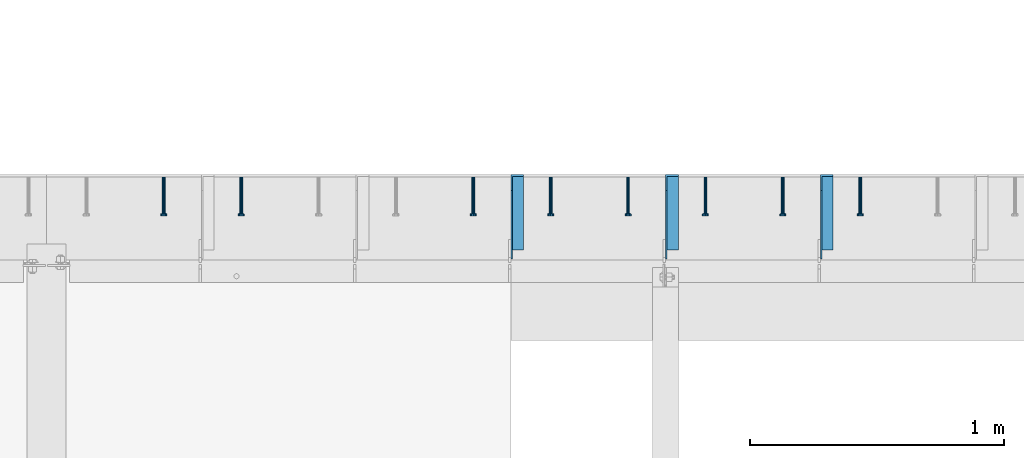
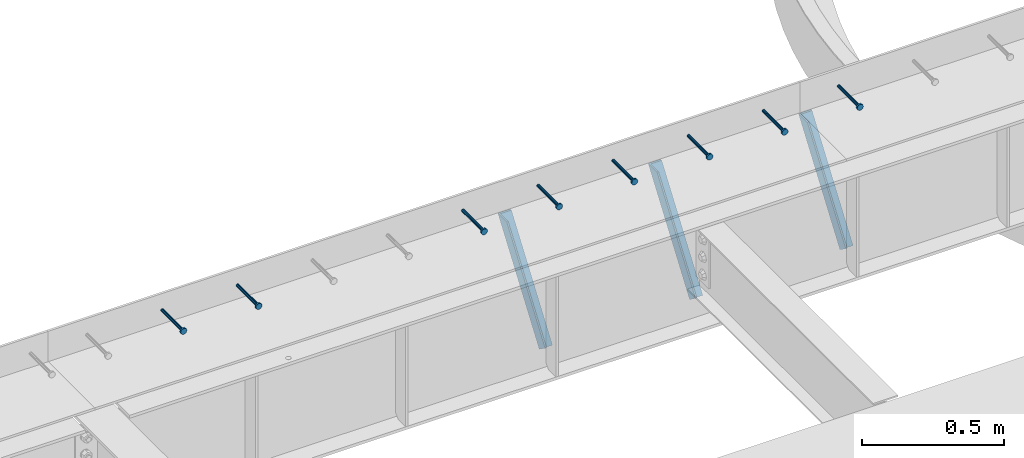
# One storey, part 1348 of 1763: 8 beams, 3 members, 9 elements without a shape of their own.
"""IFC2X3 building model written with IfcOpenShell, lengths in millimetres."""

from ifc_helpers import new_model, si_unit, frame, origin_with_axes, place, context, subcontext, project, spatial, faceted_brep, material, type_object, element, aggregate, save


model = new_model("IFC2X3")

# Units and contexts
model_context = context("Model", 3, precision=1e-05, world=origin_with_axes())
body_context = subcontext(model_context, "Body", "Model", "MODEL_VIEW")
ifc_project = project(units=[si_unit("LENGTHUNIT", "METRE", prefix="MILLI"), si_unit("AREAUNIT", "SQUARE_METRE"), si_unit("VOLUMEUNIT", "CUBIC_METRE"), si_unit("MASSUNIT", "GRAM", prefix="KILO"), si_unit("TIMEUNIT", "SECOND"), si_unit("PLANEANGLEUNIT", "RADIAN"), si_unit("SOLIDANGLEUNIT", "STERADIAN"), si_unit("THERMODYNAMICTEMPERATUREUNIT", "DEGREE_CELSIUS"), si_unit("LUMINOUSINTENSITYUNIT", "LUMEN")], contexts=[model_context])

# Site, building, storey
site_placement = place(None, origin_with_axes())
site = spatial("IfcSite", under=ifc_project, at=site_placement, CompositionType="ELEMENT")
building_placement = place(site_placement, origin_with_axes())
building = spatial("IfcBuilding", under=site, at=building_placement, Name="Undefined", CompositionType="ELEMENT")
storey_placement = place(building_placement, origin_with_axes())
storey = spatial("IfcBuildingStorey", under=building, at=storey_placement, Name="Undefined", CompositionType="ELEMENT", Elevation=0.0)

# Assembly, beam
assembly_1_placement = place(storey_placement, origin_with_axes())
assembly_1 = element("IfcElementAssembly", 1, at=assembly_1_placement, inside=storey, Name="HEADED STUD ANCHOR", AssemblyPlace="NOTDEFINED", PredefinedType="RIGID_FRAME")
ifc_material_1 = material(Name="STEEL/A108")
beam_type = type_object("IfcBeamType", PredefinedType="NOTDEFINED")
beam_1_placement = place(assembly_1_placement, frame((-58389.2747736983, 53984.5250183106, 5264.23140606069), z_axis=(0.0, 0.0, 1.0), x_axis=(0.0, -1.0, 0.0)))
beam_1 = element("IfcBeam", 2, at=beam_1_placement, type_object=beam_type, material=ifc_material_1, Name="HEADED STUD ANCHOR", context=body_context, shape_type="Brep", body=[
    faceted_brep([(0.0, -3.1800000667572, 5.5), (0.0, -5.5, 3.1800000667572), (141.732000000002, -5.5, 3.1800000667572), (141.732000000002, -3.1800000667572, 5.5), (0.0, -6.34999999999491, 1.45519152283669e-11), (141.732000000002, -6.34999990463257, 0.0), (0.0, -5.5, -3.1800000667572), (141.732000000002, -5.5, -3.1800000667572), (0.0, -3.1800000667572, -5.5), (141.732000000002, -3.1800000667572, -5.5), (0.0, 0.0, -6.34999990463257), (141.732000000002, 0.0, -6.34999990463257), (0.0, 3.1800000667572, -5.5), (141.732000000002, 3.1800000667572, -5.5), (0.0, 5.5, -3.1800000667572), (141.732000000002, 5.5, -3.1800000667572), (0.0, 6.34999999999491, -2.91038304567337e-11), (141.732000000002, 6.34999990463257, 0.0), (0.0, 5.5, 3.1800000667572), (141.732000000002, 5.5, 3.1800000667572), (0.0, 3.1800000667572, 5.5), (141.732000000002, 3.1800000667572, 5.5), (0.0, 0.0, 6.34999990463257), (141.732000000002, 0.0, 6.34999990463257), (144.780000000001, -10.9899997711182, 6.34999990463257), (144.780000000001, -6.34000015258789, 10.9899997711182), (144.780000000001, -12.6999998092651, 0.0), (144.780000000001, -10.9899997711182, -6.34999990463257), (144.780000000001, -6.34000015258789, -10.9899997711182), (144.780000000001, 0.0, -12.6899995803833), (144.780000000001, 6.34000015258789, -10.9899997711182), (144.780000000001, 10.9899997711182, -6.34999990463257), (144.780000000001, 12.6999998092651, 0.0), (144.780000000001, 10.9899997711182, 6.34999990463257), (144.780000000001, 6.34000015258789, 10.9899997711182), (144.780000000001, 0.0, 12.6899995803833), (152.400000000001, -10.9899997711182, 6.34999990463257), (152.400000000001, -6.34000015258789, 10.9899997711182), (152.400000000001, -12.6999998092651, 0.0), (152.400000000001, -10.9899997711182, -6.34999990463257), (152.400000000001, -6.34000015258789, -10.9899997711182), (152.400000000001, 0.0, -12.6899995803833), (152.400000000001, 6.34000015258789, -10.9899997711182), (152.400000000001, 10.9899997711182, -6.34999990463257), (152.400000000001, 12.6999998092651, 0.0), (152.400000000001, 10.9899997711182, 6.34999990463257), (152.400000000001, 6.34000015258789, 10.9899997711182), (152.400000000001, 0.0, 12.6899995803833)], [[[0, 1, 2, 3]], [[1, 4, 5, 2]], [[4, 6, 7, 5]], [[6, 8, 9, 7]], [[8, 10, 11, 9]], [[10, 12, 13, 11]], [[12, 14, 15, 13]], [[14, 16, 17, 15]], [[16, 18, 19, 17]], [[18, 20, 21, 19]], [[20, 22, 23, 21]], [[22, 0, 3, 23]], [[22, 20, 18, 16, 14, 12, 10, 8, 6, 4, 1, 0]], [[3, 2, 24, 25]], [[2, 5, 26, 24]], [[5, 7, 27, 26]], [[7, 9, 28, 27]], [[9, 11, 29, 28]], [[11, 13, 30, 29]], [[13, 15, 31, 30]], [[15, 17, 32, 31]], [[17, 19, 33, 32]], [[19, 21, 34, 33]], [[21, 23, 35, 34]], [[23, 3, 25, 35]], [[25, 24, 36, 37]], [[24, 26, 38, 36]], [[26, 27, 39, 38]], [[27, 28, 40, 39]], [[28, 29, 41, 40]], [[29, 30, 42, 41]], [[30, 31, 43, 42]], [[31, 32, 44, 43]], [[32, 33, 45, 44]], [[33, 34, 46, 45]], [[34, 35, 47, 46]], [[35, 25, 37, 47]], [[38, 39, 40, 41, 42, 43, 44, 45, 46, 47, 37, 36]]]),
])
aggregate(assembly_1, [beam_1])

assembly_2_placement = place(storey_placement, origin_with_axes())
assembly_2 = element("IfcElementAssembly", 3, at=assembly_2_placement, inside=storey, Name="HEADED STUD ANCHOR", AssemblyPlace="NOTDEFINED", PredefinedType="RIGID_FRAME")
beam_2_placement = place(assembly_2_placement, frame((-58694.0747736983, 53984.5250183106, 5264.23140606069), z_axis=(0.0, 0.0, 1.0), x_axis=(0.0, -1.0, 0.0)))
beam_2 = element("IfcBeam", 4, at=beam_2_placement, type_object=beam_type, material=ifc_material_1, Name="HEADED STUD ANCHOR", context=body_context, shape_type="Brep", body=[
    faceted_brep([(0.0, -3.1800000667572, 5.5), (0.0, -5.5, 3.1800000667572), (141.732000000002, -5.5, 3.1800000667572), (141.732000000002, -3.1800000667572, 5.5), (0.0, -6.34999999999491, 1.45519152283669e-11), (141.732000000002, -6.34999990463257, 0.0), (0.0, -5.5, -3.1800000667572), (141.732000000002, -5.5, -3.1800000667572), (0.0, -3.1800000667572, -5.5), (141.732000000002, -3.1800000667572, -5.5), (0.0, 0.0, -6.34999990463257), (141.732000000002, 0.0, -6.34999990463257), (0.0, 3.1800000667572, -5.5), (141.732000000002, 3.1800000667572, -5.5), (0.0, 5.5, -3.1800000667572), (141.732000000002, 5.5, -3.1800000667572), (0.0, 6.34999999999491, -2.91038304567337e-11), (141.732000000002, 6.34999990463257, 0.0), (0.0, 5.5, 3.1800000667572), (141.732000000002, 5.5, 3.1800000667572), (0.0, 3.1800000667572, 5.5), (141.732000000002, 3.1800000667572, 5.5), (0.0, 0.0, 6.34999990463257), (141.732000000002, 0.0, 6.34999990463257), (144.780000000001, -10.9899997711182, 6.34999990463257), (144.780000000001, -6.34000015258789, 10.9899997711182), (144.780000000001, -12.6999998092651, 0.0), (144.780000000001, -10.9899997711182, -6.34999990463257), (144.780000000001, -6.34000015258789, -10.9899997711182), (144.780000000001, 0.0, -12.6899995803833), (144.780000000001, 6.34000015258789, -10.9899997711182), (144.780000000001, 10.9899997711182, -6.34999990463257), (144.780000000001, 12.6999998092651, 0.0), (144.780000000001, 10.9899997711182, 6.34999990463257), (144.780000000001, 6.34000015258789, 10.9899997711182), (144.780000000001, 0.0, 12.6899995803833), (152.400000000001, -10.9899997711182, 6.34999990463257), (152.400000000001, -6.34000015258789, 10.9899997711182), (152.400000000001, -12.6999998092651, 0.0), (152.400000000001, -10.9899997711182, -6.34999990463257), (152.400000000001, -6.34000015258789, -10.9899997711182), (152.400000000001, 0.0, -12.6899995803833), (152.400000000001, 6.34000015258789, -10.9899997711182), (152.400000000001, 10.9899997711182, -6.34999990463257), (152.400000000001, 12.6999998092651, 0.0), (152.400000000001, 10.9899997711182, 6.34999990463257), (152.400000000001, 6.34000015258789, 10.9899997711182), (152.400000000001, 0.0, 12.6899995803833)], [[[0, 1, 2, 3]], [[1, 4, 5, 2]], [[4, 6, 7, 5]], [[6, 8, 9, 7]], [[8, 10, 11, 9]], [[10, 12, 13, 11]], [[12, 14, 15, 13]], [[14, 16, 17, 15]], [[16, 18, 19, 17]], [[18, 20, 21, 19]], [[20, 22, 23, 21]], [[22, 0, 3, 23]], [[22, 20, 18, 16, 14, 12, 10, 8, 6, 4, 1, 0]], [[3, 2, 24, 25]], [[2, 5, 26, 24]], [[5, 7, 27, 26]], [[7, 9, 28, 27]], [[9, 11, 29, 28]], [[11, 13, 30, 29]], [[13, 15, 31, 30]], [[15, 17, 32, 31]], [[17, 19, 33, 32]], [[19, 21, 34, 33]], [[21, 23, 35, 34]], [[23, 3, 25, 35]], [[25, 24, 36, 37]], [[24, 26, 38, 36]], [[26, 27, 39, 38]], [[27, 28, 40, 39]], [[28, 29, 41, 40]], [[29, 30, 42, 41]], [[30, 31, 43, 42]], [[31, 32, 44, 43]], [[32, 33, 45, 44]], [[33, 34, 46, 45]], [[34, 35, 47, 46]], [[35, 25, 37, 47]], [[38, 39, 40, 41, 42, 43, 44, 45, 46, 47, 37, 36]]]),
])
aggregate(assembly_2, [beam_2])

assembly_3_placement = place(storey_placement, origin_with_axes())
assembly_3 = element("IfcElementAssembly", 5, at=assembly_3_placement, inside=storey, Name="HEADED STUD ANCHOR", AssemblyPlace="NOTDEFINED", PredefinedType="RIGID_FRAME")
beam_3_placement = place(assembly_3_placement, frame((-58998.8747736983, 53984.5250183106, 5264.23140606069), z_axis=(0.0, 0.0, 1.0), x_axis=(0.0, -1.0, 0.0)))
beam_3 = element("IfcBeam", 6, at=beam_3_placement, type_object=beam_type, material=ifc_material_1, Name="HEADED STUD ANCHOR", context=body_context, shape_type="Brep", body=[
    faceted_brep([(0.0, -3.1800000667572, 5.5), (0.0, -5.5, 3.1800000667572), (141.732000000002, -5.5, 3.1800000667572), (141.732000000002, -3.1800000667572, 5.5), (0.0, -6.34999999999491, 1.45519152283669e-11), (141.732000000002, -6.34999990463257, 0.0), (0.0, -5.5, -3.1800000667572), (141.732000000002, -5.5, -3.1800000667572), (0.0, -3.1800000667572, -5.5), (141.732000000002, -3.1800000667572, -5.5), (0.0, 0.0, -6.34999990463257), (141.732000000002, 0.0, -6.34999990463257), (0.0, 3.1800000667572, -5.5), (141.732000000002, 3.1800000667572, -5.5), (0.0, 5.5, -3.1800000667572), (141.732000000002, 5.5, -3.1800000667572), (0.0, 6.34999999999491, -2.91038304567337e-11), (141.732000000002, 6.34999990463257, 0.0), (0.0, 5.5, 3.1800000667572), (141.732000000002, 5.5, 3.1800000667572), (0.0, 3.1800000667572, 5.5), (141.732000000002, 3.1800000667572, 5.5), (0.0, 0.0, 6.34999990463257), (141.732000000002, 0.0, 6.34999990463257), (144.780000000001, -10.9899997711182, 6.34999990463257), (144.780000000001, -6.34000015258789, 10.9899997711182), (144.780000000001, -12.6999998092651, 0.0), (144.780000000001, -10.9899997711182, -6.34999990463257), (144.780000000001, -6.34000015258789, -10.9899997711182), (144.780000000001, 0.0, -12.6899995803833), (144.780000000001, 6.34000015258789, -10.9899997711182), (144.780000000001, 10.9899997711182, -6.34999990463257), (144.780000000001, 12.6999998092651, 0.0), (144.780000000001, 10.9899997711182, 6.34999990463257), (144.780000000001, 6.34000015258789, 10.9899997711182), (144.780000000001, 0.0, 12.6899995803833), (152.400000000001, -10.9899997711182, 6.34999990463257), (152.400000000001, -6.34000015258789, 10.9899997711182), (152.400000000001, -12.6999998092651, 0.0), (152.400000000001, -10.9899997711182, -6.34999990463257), (152.400000000001, -6.34000015258789, -10.9899997711182), (152.400000000001, 0.0, -12.6899995803833), (152.400000000001, 6.34000015258789, -10.9899997711182), (152.400000000001, 10.9899997711182, -6.34999990463257), (152.400000000001, 12.6999998092651, 0.0), (152.400000000001, 10.9899997711182, 6.34999990463257), (152.400000000001, 6.34000015258789, 10.9899997711182), (152.400000000001, 0.0, 12.6899995803833)], [[[0, 1, 2, 3]], [[1, 4, 5, 2]], [[4, 6, 7, 5]], [[6, 8, 9, 7]], [[8, 10, 11, 9]], [[10, 12, 13, 11]], [[12, 14, 15, 13]], [[14, 16, 17, 15]], [[16, 18, 19, 17]], [[18, 20, 21, 19]], [[20, 22, 23, 21]], [[22, 0, 3, 23]], [[22, 20, 18, 16, 14, 12, 10, 8, 6, 4, 1, 0]], [[3, 2, 24, 25]], [[2, 5, 26, 24]], [[5, 7, 27, 26]], [[7, 9, 28, 27]], [[9, 11, 29, 28]], [[11, 13, 30, 29]], [[13, 15, 31, 30]], [[15, 17, 32, 31]], [[17, 19, 33, 32]], [[19, 21, 34, 33]], [[21, 23, 35, 34]], [[23, 3, 25, 35]], [[25, 24, 36, 37]], [[24, 26, 38, 36]], [[26, 27, 39, 38]], [[27, 28, 40, 39]], [[28, 29, 41, 40]], [[29, 30, 42, 41]], [[30, 31, 43, 42]], [[31, 32, 44, 43]], [[32, 33, 45, 44]], [[33, 34, 46, 45]], [[34, 35, 47, 46]], [[35, 25, 37, 47]], [[38, 39, 40, 41, 42, 43, 44, 45, 46, 47, 37, 36]]]),
])
aggregate(assembly_3, [beam_3])

assembly_4_placement = place(storey_placement, origin_with_axes())
assembly_4 = element("IfcElementAssembly", 7, at=assembly_4_placement, inside=storey, Name="HEADED STUD ANCHOR", AssemblyPlace="NOTDEFINED", PredefinedType="RIGID_FRAME")
beam_4_placement = place(assembly_4_placement, frame((-59303.6747736983, 53984.5250183106, 5264.23140606069), z_axis=(0.0, 0.0, 1.0), x_axis=(0.0, -1.0, 0.0)))
beam_4 = element("IfcBeam", 8, at=beam_4_placement, type_object=beam_type, material=ifc_material_1, Name="HEADED STUD ANCHOR", context=body_context, shape_type="Brep", body=[
    faceted_brep([(0.0, -3.1800000667572, 5.5), (0.0, -5.5, 3.1800000667572), (141.732000000002, -5.5, 3.1800000667572), (141.732000000002, -3.1800000667572, 5.5), (0.0, -6.34999999999491, 1.45519152283669e-11), (141.732000000002, -6.34999990463257, 0.0), (0.0, -5.5, -3.1800000667572), (141.732000000002, -5.5, -3.1800000667572), (0.0, -3.1800000667572, -5.5), (141.732000000002, -3.1800000667572, -5.5), (0.0, 0.0, -6.34999990463257), (141.732000000002, 0.0, -6.34999990463257), (0.0, 3.1800000667572, -5.5), (141.732000000002, 3.1800000667572, -5.5), (0.0, 5.5, -3.1800000667572), (141.732000000002, 5.5, -3.1800000667572), (0.0, 6.34999999999491, -2.91038304567337e-11), (141.732000000002, 6.34999990463257, 0.0), (0.0, 5.5, 3.1800000667572), (141.732000000002, 5.5, 3.1800000667572), (0.0, 3.1800000667572, 5.5), (141.732000000002, 3.1800000667572, 5.5), (0.0, 0.0, 6.34999990463257), (141.732000000002, 0.0, 6.34999990463257), (144.780000000001, -10.9899997711182, 6.34999990463257), (144.780000000001, -6.34000015258789, 10.9899997711182), (144.780000000001, -12.6999998092651, 0.0), (144.780000000001, -10.9899997711182, -6.34999990463257), (144.780000000001, -6.34000015258789, -10.9899997711182), (144.780000000001, 0.0, -12.6899995803833), (144.780000000001, 6.34000015258789, -10.9899997711182), (144.780000000001, 10.9899997711182, -6.34999990463257), (144.780000000001, 12.6999998092651, 0.0), (144.780000000001, 10.9899997711182, 6.34999990463257), (144.780000000001, 6.34000015258789, 10.9899997711182), (144.780000000001, 0.0, 12.6899995803833), (152.400000000001, -10.9899997711182, 6.34999990463257), (152.400000000001, -6.34000015258789, 10.9899997711182), (152.400000000001, -12.6999998092651, 0.0), (152.400000000001, -10.9899997711182, -6.34999990463257), (152.400000000001, -6.34000015258789, -10.9899997711182), (152.400000000001, 0.0, -12.6899995803833), (152.400000000001, 6.34000015258789, -10.9899997711182), (152.400000000001, 10.9899997711182, -6.34999990463257), (152.400000000001, 12.6999998092651, 0.0), (152.400000000001, 10.9899997711182, 6.34999990463257), (152.400000000001, 6.34000015258789, 10.9899997711182), (152.400000000001, 0.0, 12.6899995803833)], [[[0, 1, 2, 3]], [[1, 4, 5, 2]], [[4, 6, 7, 5]], [[6, 8, 9, 7]], [[8, 10, 11, 9]], [[10, 12, 13, 11]], [[12, 14, 15, 13]], [[14, 16, 17, 15]], [[16, 18, 19, 17]], [[18, 20, 21, 19]], [[20, 22, 23, 21]], [[22, 0, 3, 23]], [[22, 20, 18, 16, 14, 12, 10, 8, 6, 4, 1, 0]], [[3, 2, 24, 25]], [[2, 5, 26, 24]], [[5, 7, 27, 26]], [[7, 9, 28, 27]], [[9, 11, 29, 28]], [[11, 13, 30, 29]], [[13, 15, 31, 30]], [[15, 17, 32, 31]], [[17, 19, 33, 32]], [[19, 21, 34, 33]], [[21, 23, 35, 34]], [[23, 3, 25, 35]], [[25, 24, 36, 37]], [[24, 26, 38, 36]], [[26, 27, 39, 38]], [[27, 28, 40, 39]], [[28, 29, 41, 40]], [[29, 30, 42, 41]], [[30, 31, 43, 42]], [[31, 32, 44, 43]], [[32, 33, 45, 44]], [[33, 34, 46, 45]], [[34, 35, 47, 46]], [[35, 25, 37, 47]], [[38, 39, 40, 41, 42, 43, 44, 45, 46, 47, 37, 36]]]),
])
aggregate(assembly_4, [beam_4])

assembly_5_placement = place(storey_placement, origin_with_axes())
assembly_5 = element("IfcElementAssembly", 9, at=assembly_5_placement, inside=storey, Name="HEADED STUD ANCHOR", AssemblyPlace="NOTDEFINED", PredefinedType="RIGID_FRAME")
beam_5_placement = place(assembly_5_placement, frame((-59608.4747736983, 53984.5250183106, 5264.23140606069), z_axis=(0.0, 0.0, 1.0), x_axis=(0.0, -1.0, 0.0)))
beam_5 = element("IfcBeam", 10, at=beam_5_placement, type_object=beam_type, material=ifc_material_1, Name="HEADED STUD ANCHOR", context=body_context, shape_type="Brep", body=[
    faceted_brep([(0.0, -3.1800000667572, 5.5), (0.0, -5.5, 3.1800000667572), (141.732000000002, -5.5, 3.1800000667572), (141.732000000002, -3.1800000667572, 5.5), (0.0, -6.34999999999491, 1.45519152283669e-11), (141.732000000002, -6.34999990463257, 0.0), (0.0, -5.5, -3.1800000667572), (141.732000000002, -5.5, -3.1800000667572), (0.0, -3.1800000667572, -5.5), (141.732000000002, -3.1800000667572, -5.5), (0.0, 0.0, -6.34999990463257), (141.732000000002, 0.0, -6.34999990463257), (0.0, 3.1800000667572, -5.5), (141.732000000002, 3.1800000667572, -5.5), (0.0, 5.5, -3.1800000667572), (141.732000000002, 5.5, -3.1800000667572), (0.0, 6.34999999999491, -2.91038304567337e-11), (141.732000000002, 6.34999990463257, 0.0), (0.0, 5.5, 3.1800000667572), (141.732000000002, 5.5, 3.1800000667572), (0.0, 3.1800000667572, 5.5), (141.732000000002, 3.1800000667572, 5.5), (0.0, 0.0, 6.34999990463257), (141.732000000002, 0.0, 6.34999990463257), (144.780000000001, -10.9899997711182, 6.34999990463257), (144.780000000001, -6.34000015258789, 10.9899997711182), (144.780000000001, -12.6999998092651, 0.0), (144.780000000001, -10.9899997711182, -6.34999990463257), (144.780000000001, -6.34000015258789, -10.9899997711182), (144.780000000001, 0.0, -12.6899995803833), (144.780000000001, 6.34000015258789, -10.9899997711182), (144.780000000001, 10.9899997711182, -6.34999990463257), (144.780000000001, 12.6999998092651, 0.0), (144.780000000001, 10.9899997711182, 6.34999990463257), (144.780000000001, 6.34000015258789, 10.9899997711182), (144.780000000001, 0.0, 12.6899995803833), (152.400000000001, -10.9899997711182, 6.34999990463257), (152.400000000001, -6.34000015258789, 10.9899997711182), (152.400000000001, -12.6999998092651, 0.0), (152.400000000001, -10.9899997711182, -6.34999990463257), (152.400000000001, -6.34000015258789, -10.9899997711182), (152.400000000001, 0.0, -12.6899995803833), (152.400000000001, 6.34000015258789, -10.9899997711182), (152.400000000001, 10.9899997711182, -6.34999990463257), (152.400000000001, 12.6999998092651, 0.0), (152.400000000001, 10.9899997711182, 6.34999990463257), (152.400000000001, 6.34000015258789, 10.9899997711182), (152.400000000001, 0.0, 12.6899995803833)], [[[0, 1, 2, 3]], [[1, 4, 5, 2]], [[4, 6, 7, 5]], [[6, 8, 9, 7]], [[8, 10, 11, 9]], [[10, 12, 13, 11]], [[12, 14, 15, 13]], [[14, 16, 17, 15]], [[16, 18, 19, 17]], [[18, 20, 21, 19]], [[20, 22, 23, 21]], [[22, 0, 3, 23]], [[22, 20, 18, 16, 14, 12, 10, 8, 6, 4, 1, 0]], [[3, 2, 24, 25]], [[2, 5, 26, 24]], [[5, 7, 27, 26]], [[7, 9, 28, 27]], [[9, 11, 29, 28]], [[11, 13, 30, 29]], [[13, 15, 31, 30]], [[15, 17, 32, 31]], [[17, 19, 33, 32]], [[19, 21, 34, 33]], [[21, 23, 35, 34]], [[23, 3, 25, 35]], [[25, 24, 36, 37]], [[24, 26, 38, 36]], [[26, 27, 39, 38]], [[27, 28, 40, 39]], [[28, 29, 41, 40]], [[29, 30, 42, 41]], [[30, 31, 43, 42]], [[31, 32, 44, 43]], [[32, 33, 45, 44]], [[33, 34, 46, 45]], [[34, 35, 47, 46]], [[35, 25, 37, 47]], [[38, 39, 40, 41, 42, 43, 44, 45, 46, 47, 37, 36]]]),
])
aggregate(assembly_5, [beam_5])

assembly_6_placement = place(storey_placement, origin_with_axes())
assembly_6 = element("IfcElementAssembly", 11, at=assembly_6_placement, inside=storey, Name="HEADED STUD ANCHOR", AssemblyPlace="NOTDEFINED", PredefinedType="RIGID_FRAME")
beam_6_placement = place(assembly_6_placement, frame((-59913.2747736983, 53984.5250183106, 5264.23140606069), z_axis=(0.0, 0.0, 1.0), x_axis=(0.0, -1.0, 0.0)))
beam_6 = element("IfcBeam", 12, at=beam_6_placement, type_object=beam_type, material=ifc_material_1, Name="HEADED STUD ANCHOR", context=body_context, shape_type="Brep", body=[
    faceted_brep([(0.0, -3.1800000667572, 5.5), (0.0, -5.5, 3.1800000667572), (141.732000000002, -5.5, 3.1800000667572), (141.732000000002, -3.1800000667572, 5.5), (0.0, -6.34999999999491, 1.45519152283669e-11), (141.732000000002, -6.34999990463257, 0.0), (0.0, -5.5, -3.1800000667572), (141.732000000002, -5.5, -3.1800000667572), (0.0, -3.1800000667572, -5.5), (141.732000000002, -3.1800000667572, -5.5), (0.0, 0.0, -6.34999990463257), (141.732000000002, 0.0, -6.34999990463257), (0.0, 3.1800000667572, -5.5), (141.732000000002, 3.1800000667572, -5.5), (0.0, 5.5, -3.1800000667572), (141.732000000002, 5.5, -3.1800000667572), (0.0, 6.34999999999491, -2.91038304567337e-11), (141.732000000002, 6.34999990463257, 0.0), (0.0, 5.5, 3.1800000667572), (141.732000000002, 5.5, 3.1800000667572), (0.0, 3.1800000667572, 5.5), (141.732000000002, 3.1800000667572, 5.5), (0.0, 0.0, 6.34999990463257), (141.732000000002, 0.0, 6.34999990463257), (144.780000000001, -10.9899997711182, 6.34999990463257), (144.780000000001, -6.34000015258789, 10.9899997711182), (144.780000000001, -12.6999998092651, 0.0), (144.780000000001, -10.9899997711182, -6.34999990463257), (144.780000000001, -6.34000015258789, -10.9899997711182), (144.780000000001, 0.0, -12.6899995803833), (144.780000000001, 6.34000015258789, -10.9899997711182), (144.780000000001, 10.9899997711182, -6.34999990463257), (144.780000000001, 12.6999998092651, 0.0), (144.780000000001, 10.9899997711182, 6.34999990463257), (144.780000000001, 6.34000015258789, 10.9899997711182), (144.780000000001, 0.0, 12.6899995803833), (152.400000000001, -10.9899997711182, 6.34999990463257), (152.400000000001, -6.34000015258789, 10.9899997711182), (152.400000000001, -12.6999998092651, 0.0), (152.400000000001, -10.9899997711182, -6.34999990463257), (152.400000000001, -6.34000015258789, -10.9899997711182), (152.400000000001, 0.0, -12.6899995803833), (152.400000000001, 6.34000015258789, -10.9899997711182), (152.400000000001, 10.9899997711182, -6.34999990463257), (152.400000000001, 12.6999998092651, 0.0), (152.400000000001, 10.9899997711182, 6.34999990463257), (152.400000000001, 6.34000015258789, 10.9899997711182), (152.400000000001, 0.0, 12.6899995803833)], [[[0, 1, 2, 3]], [[1, 4, 5, 2]], [[4, 6, 7, 5]], [[6, 8, 9, 7]], [[8, 10, 11, 9]], [[10, 12, 13, 11]], [[12, 14, 15, 13]], [[14, 16, 17, 15]], [[16, 18, 19, 17]], [[18, 20, 21, 19]], [[20, 22, 23, 21]], [[22, 0, 3, 23]], [[22, 20, 18, 16, 14, 12, 10, 8, 6, 4, 1, 0]], [[3, 2, 24, 25]], [[2, 5, 26, 24]], [[5, 7, 27, 26]], [[7, 9, 28, 27]], [[9, 11, 29, 28]], [[11, 13, 30, 29]], [[13, 15, 31, 30]], [[15, 17, 32, 31]], [[17, 19, 33, 32]], [[19, 21, 34, 33]], [[21, 23, 35, 34]], [[23, 3, 25, 35]], [[25, 24, 36, 37]], [[24, 26, 38, 36]], [[26, 27, 39, 38]], [[27, 28, 40, 39]], [[28, 29, 41, 40]], [[29, 30, 42, 41]], [[30, 31, 43, 42]], [[31, 32, 44, 43]], [[32, 33, 45, 44]], [[33, 34, 46, 45]], [[34, 35, 47, 46]], [[35, 25, 37, 47]], [[38, 39, 40, 41, 42, 43, 44, 45, 46, 47, 37, 36]]]),
])
aggregate(assembly_6, [beam_6])

assembly_7_placement = place(storey_placement, origin_with_axes())
assembly_7 = element("IfcElementAssembly", 13, at=assembly_7_placement, inside=storey, Name="HEADED STUD ANCHOR", AssemblyPlace="NOTDEFINED", PredefinedType="RIGID_FRAME")
beam_7_placement = place(assembly_7_placement, frame((-60827.6747736983, 53984.5250183106, 5264.23140606069), z_axis=(0.0, 0.0, 1.0), x_axis=(0.0, -1.0, 0.0)))
beam_7 = element("IfcBeam", 14, at=beam_7_placement, type_object=beam_type, material=ifc_material_1, Name="HEADED STUD ANCHOR", context=body_context, shape_type="Brep", body=[
    faceted_brep([(0.0, -3.1800000667572, 5.5), (0.0, -5.5, 3.1800000667572), (141.732000000002, -5.5, 3.1800000667572), (141.732000000002, -3.1800000667572, 5.5), (0.0, -6.34999999999491, 1.45519152283669e-11), (141.732000000002, -6.34999990463257, 0.0), (0.0, -5.5, -3.1800000667572), (141.732000000002, -5.5, -3.1800000667572), (0.0, -3.1800000667572, -5.5), (141.732000000002, -3.1800000667572, -5.5), (0.0, 0.0, -6.34999990463257), (141.732000000002, 0.0, -6.34999990463257), (0.0, 3.1800000667572, -5.5), (141.732000000002, 3.1800000667572, -5.5), (0.0, 5.5, -3.1800000667572), (141.732000000002, 5.5, -3.1800000667572), (0.0, 6.34999999999491, -2.91038304567337e-11), (141.732000000002, 6.34999990463257, 0.0), (0.0, 5.5, 3.1800000667572), (141.732000000002, 5.5, 3.1800000667572), (0.0, 3.1800000667572, 5.5), (141.732000000002, 3.1800000667572, 5.5), (0.0, 0.0, 6.34999990463257), (141.732000000002, 0.0, 6.34999990463257), (144.780000000001, -10.9899997711182, 6.34999990463257), (144.780000000001, -6.34000015258789, 10.9899997711182), (144.780000000001, -12.6999998092651, 0.0), (144.780000000001, -10.9899997711182, -6.34999990463257), (144.780000000001, -6.34000015258789, -10.9899997711182), (144.780000000001, 0.0, -12.6899995803833), (144.780000000001, 6.34000015258789, -10.9899997711182), (144.780000000001, 10.9899997711182, -6.34999990463257), (144.780000000001, 12.6999998092651, 0.0), (144.780000000001, 10.9899997711182, 6.34999990463257), (144.780000000001, 6.34000015258789, 10.9899997711182), (144.780000000001, 0.0, 12.6899995803833), (152.400000000001, -10.9899997711182, 6.34999990463257), (152.400000000001, -6.34000015258789, 10.9899997711182), (152.400000000001, -12.6999998092651, 0.0), (152.400000000001, -10.9899997711182, -6.34999990463257), (152.400000000001, -6.34000015258789, -10.9899997711182), (152.400000000001, 0.0, -12.6899995803833), (152.400000000001, 6.34000015258789, -10.9899997711182), (152.400000000001, 10.9899997711182, -6.34999990463257), (152.400000000001, 12.6999998092651, 0.0), (152.400000000001, 10.9899997711182, 6.34999990463257), (152.400000000001, 6.34000015258789, 10.9899997711182), (152.400000000001, 0.0, 12.6899995803833)], [[[0, 1, 2, 3]], [[1, 4, 5, 2]], [[4, 6, 7, 5]], [[6, 8, 9, 7]], [[8, 10, 11, 9]], [[10, 12, 13, 11]], [[12, 14, 15, 13]], [[14, 16, 17, 15]], [[16, 18, 19, 17]], [[18, 20, 21, 19]], [[20, 22, 23, 21]], [[22, 0, 3, 23]], [[22, 20, 18, 16, 14, 12, 10, 8, 6, 4, 1, 0]], [[3, 2, 24, 25]], [[2, 5, 26, 24]], [[5, 7, 27, 26]], [[7, 9, 28, 27]], [[9, 11, 29, 28]], [[11, 13, 30, 29]], [[13, 15, 31, 30]], [[15, 17, 32, 31]], [[17, 19, 33, 32]], [[19, 21, 34, 33]], [[21, 23, 35, 34]], [[23, 3, 25, 35]], [[25, 24, 36, 37]], [[24, 26, 38, 36]], [[26, 27, 39, 38]], [[27, 28, 40, 39]], [[28, 29, 41, 40]], [[29, 30, 42, 41]], [[30, 31, 43, 42]], [[31, 32, 44, 43]], [[32, 33, 45, 44]], [[33, 34, 46, 45]], [[34, 35, 47, 46]], [[35, 25, 37, 47]], [[38, 39, 40, 41, 42, 43, 44, 45, 46, 47, 37, 36]]]),
])
aggregate(assembly_7, [beam_7])

assembly_8_placement = place(storey_placement, origin_with_axes())
assembly_8 = element("IfcElementAssembly", 15, at=assembly_8_placement, inside=storey, Name="HEADED STUD ANCHOR", AssemblyPlace="NOTDEFINED", PredefinedType="RIGID_FRAME")
beam_8_placement = place(assembly_8_placement, frame((-61132.4747736983, 53984.5250183106, 5264.23140606069), z_axis=(0.0, 0.0, 1.0), x_axis=(0.0, -1.0, 0.0)))
beam_8 = element("IfcBeam", 16, at=beam_8_placement, type_object=beam_type, material=ifc_material_1, Name="HEADED STUD ANCHOR", context=body_context, shape_type="Brep", body=[
    faceted_brep([(0.0, -3.1800000667572, 5.5), (0.0, -5.5, 3.1800000667572), (141.732000000002, -5.5, 3.1800000667572), (141.732000000002, -3.1800000667572, 5.5), (0.0, -6.34999999999491, 1.45519152283669e-11), (141.732000000002, -6.34999990463257, 0.0), (0.0, -5.5, -3.1800000667572), (141.732000000002, -5.5, -3.1800000667572), (0.0, -3.1800000667572, -5.5), (141.732000000002, -3.1800000667572, -5.5), (0.0, 0.0, -6.34999990463257), (141.732000000002, 0.0, -6.34999990463257), (0.0, 3.1800000667572, -5.5), (141.732000000002, 3.1800000667572, -5.5), (0.0, 5.5, -3.1800000667572), (141.732000000002, 5.5, -3.1800000667572), (0.0, 6.34999999999491, -2.91038304567337e-11), (141.732000000002, 6.34999990463257, 0.0), (0.0, 5.5, 3.1800000667572), (141.732000000002, 5.5, 3.1800000667572), (0.0, 3.1800000667572, 5.5), (141.732000000002, 3.1800000667572, 5.5), (0.0, 0.0, 6.34999990463257), (141.732000000002, 0.0, 6.34999990463257), (144.780000000001, -10.9899997711182, 6.34999990463257), (144.780000000001, -6.34000015258789, 10.9899997711182), (144.780000000001, -12.6999998092651, 0.0), (144.780000000001, -10.9899997711182, -6.34999990463257), (144.780000000001, -6.34000015258789, -10.9899997711182), (144.780000000001, 0.0, -12.6899995803833), (144.780000000001, 6.34000015258789, -10.9899997711182), (144.780000000001, 10.9899997711182, -6.34999990463257), (144.780000000001, 12.6999998092651, 0.0), (144.780000000001, 10.9899997711182, 6.34999990463257), (144.780000000001, 6.34000015258789, 10.9899997711182), (144.780000000001, 0.0, 12.6899995803833), (152.400000000001, -10.9899997711182, 6.34999990463257), (152.400000000001, -6.34000015258789, 10.9899997711182), (152.400000000001, -12.6999998092651, 0.0), (152.400000000001, -10.9899997711182, -6.34999990463257), (152.400000000001, -6.34000015258789, -10.9899997711182), (152.400000000001, 0.0, -12.6899995803833), (152.400000000001, 6.34000015258789, -10.9899997711182), (152.400000000001, 10.9899997711182, -6.34999990463257), (152.400000000001, 12.6999998092651, 0.0), (152.400000000001, 10.9899997711182, 6.34999990463257), (152.400000000001, 6.34000015258789, 10.9899997711182), (152.400000000001, 0.0, 12.6899995803833)], [[[0, 1, 2, 3]], [[1, 4, 5, 2]], [[4, 6, 7, 5]], [[6, 8, 9, 7]], [[8, 10, 11, 9]], [[10, 12, 13, 11]], [[12, 14, 15, 13]], [[14, 16, 17, 15]], [[16, 18, 19, 17]], [[18, 20, 21, 19]], [[20, 22, 23, 21]], [[22, 0, 3, 23]], [[22, 20, 18, 16, 14, 12, 10, 8, 6, 4, 1, 0]], [[3, 2, 24, 25]], [[2, 5, 26, 24]], [[5, 7, 27, 26]], [[7, 9, 28, 27]], [[9, 11, 29, 28]], [[11, 13, 30, 29]], [[13, 15, 31, 30]], [[15, 17, 32, 31]], [[17, 19, 33, 32]], [[19, 21, 34, 33]], [[21, 23, 35, 34]], [[23, 3, 25, 35]], [[25, 24, 36, 37]], [[24, 26, 38, 36]], [[26, 27, 39, 38]], [[27, 28, 40, 39]], [[28, 29, 41, 40]], [[29, 30, 42, 41]], [[30, 31, 43, 42]], [[31, 32, 44, 43]], [[32, 33, 45, 44]], [[33, 34, 46, 45]], [[34, 35, 47, 46]], [[35, 25, 37, 47]], [[38, 39, 40, 41, 42, 43, 44, 45, 46, 47, 37, 36]]]),
])
aggregate(assembly_8, [beam_8])

# Assembly, members
assembly_9_placement = place(storey_placement, origin_with_axes())
assembly_9 = element("IfcElementAssembly", 17, at=assembly_9_placement, inside=storey, Name="BEAM", AssemblyPlace="NOTDEFINED", PredefinedType="RIGID_FRAME")
ifc_material_2 = material(Name="STEEL/A36")
member_type = type_object("IfcMemberType", Name="L2X2X1/4", PredefinedType="NOTDEFINED")
member_1_placement = place(assembly_9_placement, frame((-59130.6372736984, 53682.7083833992, 4801.551610525), z_axis=(0.0, -0.814117947745209, 0.580699549818259), x_axis=(0.0, 0.58069954981826, 0.814117947745209)))
member_1 = element("IfcMember", 18, at=member_1_placement, type_object=member_type, material=ifc_material_2, Name="ANGLE", ObjectType="L2X2X1/4", context=body_context, shape_type="Brep", body=[
    faceted_brep([(-1.45519152283669e-11, 25.4000000000015, -25.3999999999869), (1.45519152283669e-11, 25.4000000000015, 25.3999999999796), (464.304493432646, 25.4000000000015, 25.3999999991429), (500.539460322936, 25.4000000000015, -25.4000000009546), (1.45519152283669e-11, 19.0499999999993, 25.3999999999796), (464.304493432646, 19.0500000000029, 25.3999999991429), (-7.27595761418343e-12, 19.0499999999993, -19.0499999999956), (496.010089461648, 19.0500000000029, -19.0500000009415), (-7.27595761418343e-12, -25.4000000000015, -19.0499999999956), (496.010089461648, -25.4000000000015, -19.0500000009415), (-1.45519152283669e-11, -25.4000000000015, -25.3999999999869), (500.539460322936, -25.4000000000015, -25.4000000009546)], [[[0, 1, 2, 3]], [[1, 4, 5, 2]], [[4, 6, 7, 5]], [[6, 8, 9, 7]], [[8, 10, 11, 9]], [[10, 0, 3, 11]], [[5, 7, 9, 11, 3, 2]], [[10, 8, 6, 4, 1, 0]]]),
])
member_2_placement = place(assembly_9_placement, frame((-58521.0372736983, 53682.7083833992, 4801.551610525), z_axis=(0.0, -0.814117947745209, 0.580699549818259), x_axis=(0.0, 0.58069954981826, 0.814117947745209)))
member_2 = element("IfcMember", 19, at=member_2_placement, type_object=member_type, material=ifc_material_2, Name="ANGLE", ObjectType="L2X2X1/4", context=body_context, shape_type="Brep", body=[
    faceted_brep([(-1.45519152283669e-11, 25.4000000000015, -25.3999999999869), (1.45519152283669e-11, 25.4000000000015, 25.3999999999796), (464.304493432646, 25.4000000000015, 25.3999999991429), (500.539460322936, 25.4000000000015, -25.4000000009546), (1.45519152283669e-11, 19.0499999999993, 25.3999999999796), (464.304493432646, 19.0500000000029, 25.3999999991429), (-7.27595761418343e-12, 19.0499999999993, -19.0499999999956), (496.010089461648, 19.0500000000029, -19.0500000009415), (-7.27595761418343e-12, -25.4000000000015, -19.0499999999956), (496.010089461648, -25.4000000000015, -19.0500000009415), (-1.45519152283669e-11, -25.4000000000015, -25.3999999999869), (500.539460322936, -25.4000000000015, -25.4000000009546)], [[[0, 1, 2, 3]], [[1, 4, 5, 2]], [[4, 6, 7, 5]], [[6, 8, 9, 7]], [[8, 10, 11, 9]], [[10, 0, 3, 11]], [[5, 7, 9, 11, 3, 2]], [[10, 8, 6, 4, 1, 0]]]),
])
member_3_placement = place(assembly_9_placement, frame((-59740.2372736984, 53682.7083833992, 4801.551610525), z_axis=(0.0, -0.814117947745209, 0.580699549818259), x_axis=(0.0, 0.58069954981826, 0.814117947745209)))
member_3 = element("IfcMember", 20, at=member_3_placement, type_object=member_type, material=ifc_material_2, Name="ANGLE", ObjectType="L2X2X1/4", context=body_context, shape_type="Brep", body=[
    faceted_brep([(-1.45519152283669e-11, 25.4000000000015, -25.3999999999869), (1.45519152283669e-11, 25.4000000000015, 25.3999999999796), (464.304493432646, 25.4000000000015, 25.3999999991429), (500.539460322936, 25.4000000000015, -25.4000000009546), (1.45519152283669e-11, 19.0499999999993, 25.3999999999796), (464.304493432646, 19.0500000000029, 25.3999999991429), (-7.27595761418343e-12, 19.0499999999993, -19.0499999999956), (496.010089461648, 19.0500000000029, -19.0500000009415), (-7.27595761418343e-12, -25.4000000000015, -19.0499999999956), (496.010089461648, -25.4000000000015, -19.0500000009415), (-1.45519152283669e-11, -25.4000000000015, -25.3999999999869), (500.539460322936, -25.4000000000015, -25.4000000009546)], [[[0, 1, 2, 3]], [[1, 4, 5, 2]], [[4, 6, 7, 5]], [[6, 8, 9, 7]], [[8, 10, 11, 9]], [[10, 0, 3, 11]], [[5, 7, 9, 11, 3, 2]], [[10, 8, 6, 4, 1, 0]]]),
])
aggregate(assembly_9, [member_1, member_2, member_3])

save(model, "model.ifc")
